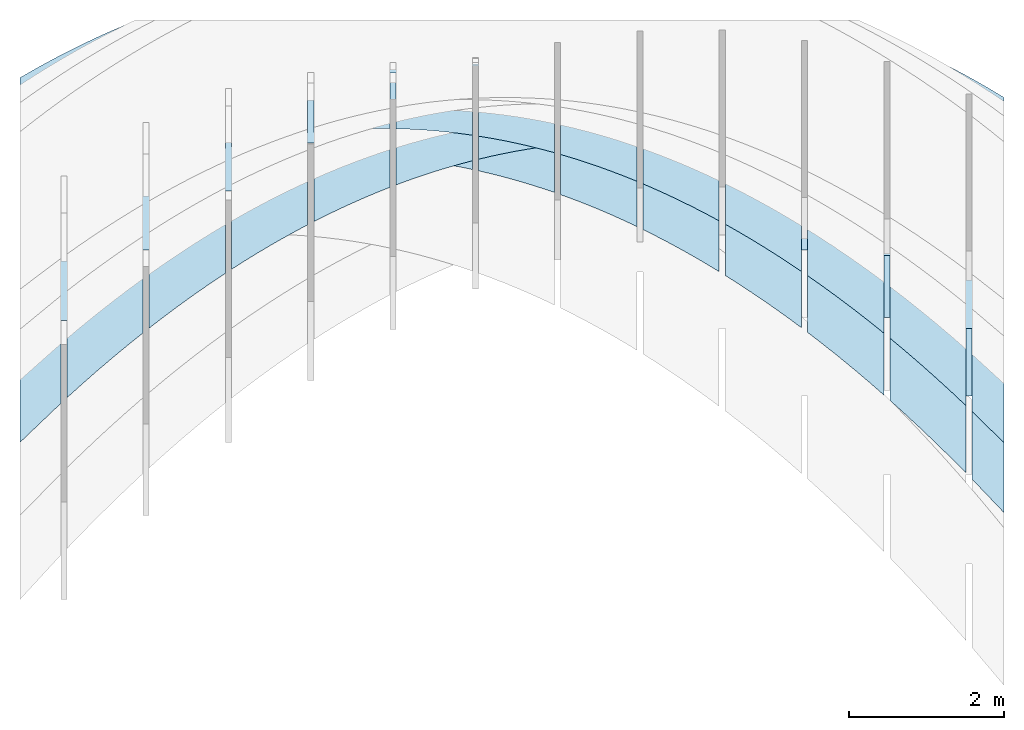
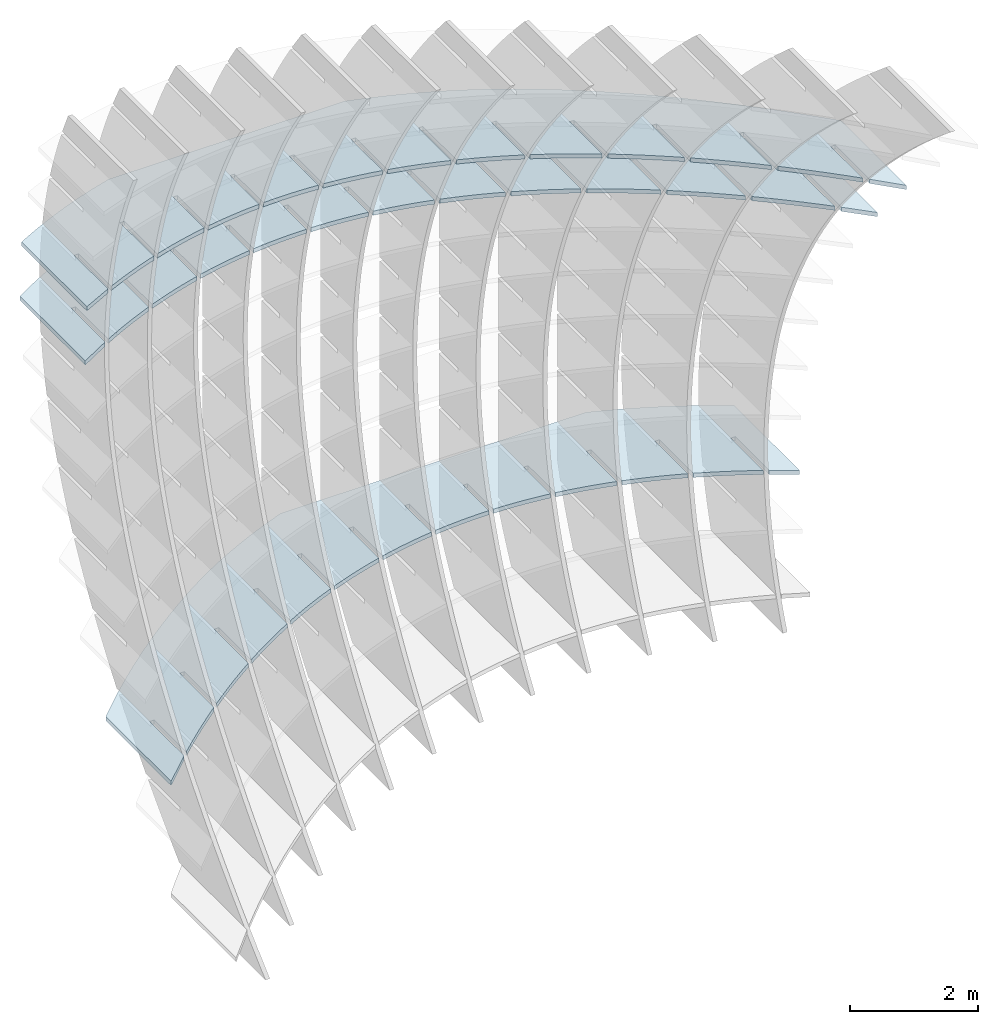
# Not in any storey, part 2 of 9: 3 slabs.
"""IFC2X3 building model written with IfcOpenShell, lengths in metres."""

from ifc_helpers import new_model, si_unit, point, direction, frame, frame_2d, origin_with_axes, place, context, project, spatial, polyline, circle_curve, parameter, trimmed, segment, composite_curve, outline, extrude, material, layer, layer_set, layer_usage, type_object, element, save


model = new_model("IFC2X3")

# Units and contexts
model_context = context("Model", 3, precision=2.54e-06, world=origin_with_axes(), true_north=direction((0.0, 1.0)), identifier="Body")
ifc_project = project(units=[si_unit("LENGTHUNIT", "METRE"), si_unit("AREAUNIT", "SQUARE_METRE"), si_unit("VOLUMEUNIT", "CUBIC_METRE"), si_unit("PLANEANGLEUNIT", "RADIAN")], contexts=[model_context])

# Building
building_placement = place(None, origin_with_axes())
building = spatial("IfcBuilding", under=ifc_project, at=building_placement, Name="Building", CompositionType="ELEMENT")

# Slabs
ifc_material = material(Name="MATERIAL")
ifc_layer = layer(ifc_material, 0.07874, ventilated=True)
ifc_layer_set = layer_set([ifc_layer], Name="SLAB")
ifc_layer_usage_1 = layer_usage(ifc_layer_set, "AXIS3", "NEGATIVE", -0.07874)
slab_type = type_object("IfcSlabType", Name="SLAB", PredefinedType="FLOOR", material=ifc_material)
slab_1_placement = place(None, frame((6.71456553163902, -0.140076335961218, 3.57420189527537), z_axis=(0.0, 0.0, 1.0), x_axis=(-0.89945391, -0.43701564, 0.0)))
element("IfcSlab", 1, at=slab_1_placement, inside=building, type_object=slab_type, material=ifc_layer_usage_1, PredefinedType="FLOOR", context=model_context, shape_type="SweptSolid", body=[
    extrude(outline(composite_curve([segment(polyline([(0.0, 0.0), (0.585873331497038, 0.0)]), True, "CONTINUOUS"), segment(polyline([(0.585873331497038, 0.0), (-0.302142439822155, -1.82769034299806)]), True, "CONTINUOUS"), segment(trimmed(circle_curve(frame_2d((-0.628341243734594, 8.08792664630792), x_axis=(-0.18567938, -0.98261038)), 9.92098109756728), [parameter(0.21964883740824), point((-0.302142439822155, -1.82769034299806))], [parameter(0.0), point((-2.47046284071556, -1.66053240936973))], False, "PARAMETER"), True, "CONTINUOUS"), segment(polyline([(-2.47046284071556, -1.66053240936973), (-6.2862334238149, 0.19342740964954)]), True, "CONTINUOUS"), segment(trimmed(circle_curve(frame_2d((0.781807774238855, 8.17662836836214), x_axis=(-0.86506458, -0.50166051)), 10.6624905122853), [parameter(0.32060910301311), point((-6.2862334238149, 0.19342740964954))], [parameter(0.0), point((-8.44193510839154, 2.82767789563386))], False, "PARAMETER"), True, "CONTINUOUS"), segment(trimmed(circle_curve(frame_2d((4.9780248630452, 10.7740982040003), x_axis=(-0.91693308, -0.399041)), 15.5961829096796), [parameter(0.124145184545443), point((-8.44193510839154, 2.82767789563386))], [parameter(0.0), point((-9.32263121565005, 4.55058174856616))], False, "PARAMETER"), True, "CONTINUOUS"), segment(trimmed(circle_curve(frame_2d((10.2535347681565, 13.0618712359868), x_axis=(-0.95738023, -0.28883058)), 21.3463890005832), [parameter(0.117118469446826), point((-9.32263121565005, 4.55058174856616))], [parameter(0.0), point((-10.1830759507192, 6.89638133741767))], False, "PARAMETER"), True, "CONTINUOUS"), segment(polyline([(-10.1830759507192, 6.89638133741767), (-9.29506017939982, 8.72407168041523)]), True, "CONTINUOUS"), segment(polyline([(-9.29506017939982, 8.72407168041523), (-9.11391498822793, 8.15804572744072)]), True, "CONTINUOUS"), segment(polyline([(-9.11391498822793, 8.15804572744072), (-9.58386503322145, 7.19080709647565)]), True, "CONTINUOUS"), segment(polyline([(-9.58386503322145, 7.19080709647565), (-9.51304203243027, 7.15639648533703)]), True, "CONTINUOUS"), segment(polyline([(-9.51304203243027, 7.15639648533703), (-9.07824061056723, 8.05129315894045)]), True, "CONTINUOUS"), segment(trimmed(circle_curve(frame_2d((10.5986194787214, 14.6501848580907), x_axis=(-0.9481044, -0.31795918)), 20.7538958904239), [parameter(0.0), point((-9.07824061056723, 8.05129315894045))], [parameter(0.0655223084688651), point((-8.60395233100186, 6.77710220115287))], True, "PARAMETER"), True, "CONTINUOUS"), segment(polyline([(-8.60395233100186, 6.77710220115287), (-9.07159581147442, 5.81461087968119)]), True, "CONTINUOUS"), segment(polyline([(-9.07159581147442, 5.81461087968119), (-9.00077281068325, 5.78020026854257)]), True, "CONTINUOUS"), segment(polyline([(-9.00077281068325, 5.78020026854257), (-8.56366488580851, 6.67984412504151)]), True, "CONTINUOUS"), segment(trimmed(circle_curve(frame_2d((7.29840051263215, 13.2814892771154), x_axis=(-0.92323284, -0.38424098)), 17.181002223919), [parameter(0.0), point((-8.56366488580851, 6.67984412504151))], [parameter(0.0740579088368072), point((-8.03172917602346, 5.52430156846033))], True, "PARAMETER"), True, "CONTINUOUS"), segment(polyline([(-8.03172917602346, 5.52430156846033), (-8.49707027378661, 4.56654894958593)]), True, "CONTINUOUS"), segment(polyline([(-8.49707027378661, 4.56654894958593), (-8.42624727299543, 4.53213833844731)]), True, "CONTINUOUS"), segment(polyline([(-8.42624727299543, 4.53213833844731), (-7.98683696541178, 5.43652089754465)]), True, "CONTINUOUS"), segment(trimmed(circle_curve(frame_2d((4.6180486886762, 11.9140727940524), x_axis=(-0.88943013, -0.45707117)), 14.1718672349336), [parameter(0.0), point((-7.98683696541178, 5.43652089754465))], [parameter(0.0842035553852745), point((-7.39738895089196, 4.39934863050301))], True, "PARAMETER"), True, "CONTINUOUS"), segment(polyline([(-7.39738895089196, 4.39934863050301), (-7.86042766594634, 3.44633471422733)]), True, "CONTINUOUS"), segment(polyline([(-7.86042766594634, 3.44633471422733), (-7.78960466515517, 3.41192410308871)]), True, "CONTINUOUS"), segment(polyline([(-7.78960466515517, 3.41192410308871), (-7.34789197486261, 4.32104536478444)]), True, "CONTINUOUS"), segment(trimmed(circle_curve(frame_2d((2.65077584759879, 10.6742793642747), x_axis=(-0.84402661, -0.5363013)), 11.8463893434331), [parameter(0.0), point((-7.34789197486261, 4.32104536478444))], [parameter(0.0948934985891332), point((-6.70093165560826, 3.40224338728277))], True, "PARAMETER"), True, "CONTINUOUS"), segment(polyline([(-6.70093165560826, 3.40224338728277), (-7.16166798795364, 2.4539681736054)]), True, "CONTINUOUS"), segment(polyline([(-7.16166798795364, 2.4539681736054), (-7.09084498716247, 2.41955756246678)]), True, "CONTINUOUS"), segment(polyline([(-7.09084498716247, 2.41955756246678), (-6.646829914161, 3.33341752676089)]), True, "CONTINUOUS"), segment(trimmed(circle_curve(frame_2d((1.29393191304388, 9.61198334810849), x_axis=(-0.78442405, -0.62022488)), 10.1230473262446), [parameter(0.0), point((-6.646829914161, 3.33341752676089))], [parameter(0.10538157879388), point((-5.94235729017195, 2.53298583879896))], True, "PARAMETER"), True, "CONTINUOUS"), segment(polyline([(-5.94235729017195, 2.53298583879896), (-6.4007912398085, 1.58944932772011)]), True, "CONTINUOUS"), segment(polyline([(-6.4007912398085, 1.58944932772011), (-6.32996823901732, 1.55503871658149)]), True, "CONTINUOUS"), segment(polyline([(-6.32996823901732, 1.55503871658149), (-5.88365078330694, 2.473637383474)]), True, "CONTINUOUS"), segment(trimmed(circle_curve(frame_2d((0.444866808654828, 8.77705910587912), x_axis=(-0.70851019, -0.70570058)), 8.93214757615762), [parameter(0.0), point((-5.88365078330694, 2.473637383474))], [parameter(0.114554431580325), point((-5.1216658545834, 1.79157598505202))], True, "PARAMETER"), True, "CONTINUOUS"), segment(polyline([(-5.1216658545834, 1.79157598505202), (-5.55719284104637, 0.895185973767041)]), True, "CONTINUOUS"), segment(polyline([(-5.55719284104637, 0.895185973767041), (-5.48636984025519, 0.860775362628422)]), True, "CONTINUOUS"), segment(polyline([(-5.48636984025519, 0.860775362628422), (-5.05835458230043, 1.74170493492376)]), True, "CONTINUOUS"), segment(trimmed(circle_curve(frame_2d((0.00093045807611101, 8.21938099791285), x_axis=(-0.61553831, -0.78810697)), 8.21928538845074), [parameter(0.0), point((-5.05835458230043, 1.74170493492376))], [parameter(0.121087811880619), point((-4.23885734884193, 1.17801382604141))], True, "PARAMETER"), True, "CONTINUOUS"), segment(polyline([(-4.23885734884193, 1.17801382604141), (-4.63694560262867, 0.358679214420813)]), True, "CONTINUOUS"), segment(polyline([(-4.63694560262867, 0.358679214420813), (-4.5661226018375, 0.324268603282195)]), True, "CONTINUOUS"), segment(polyline([(-4.5661226018375, 0.324268603282195), (-4.17094131114149, 1.13762018111019)]), True, "CONTINUOUS"), segment(trimmed(circle_curve(frame_2d((-0.140527215047963, 7.98882338453596), x_axis=(-0.50704766, -0.86191802)), 7.9487875251903), [parameter(0.0), point((-4.17094131114149, 1.13762018111019))], [parameter(0.123820419877384), point((-3.29393177294847, 0.692299361767771))], True, "PARAMETER"), True, "CONTINUOUS"), segment(polyline([(-3.29393177294847, 0.692299361767771), (-3.68563982913476, -0.113903697557086)]), True, "CONTINUOUS"), segment(polyline([(-3.68563982913476, -0.113903697557086), (-3.61481682834358, -0.148314308695705)]), True, "CONTINUOUS"), segment(polyline([(-3.61481682834358, -0.148314308695705), (-3.2214109698301, 0.661383122033269)]), True, "CONTINUOUS"), segment(trimmed(circle_curve(frame_2d((-0.0821562870734553, 8.13526062607407), x_axis=(-0.3872562, -0.92197215)), 8.10640271073531), [parameter(0.0), point((-3.2214109698301, 0.661383122033269))], [parameter(0.122209681178168), point((-2.28688912690253, 0.334432592230744))], True, "PARAMETER"), True, "CONTINUOUS"), segment(polyline([(-2.28688912690253, 0.334432592230744), (-2.70327552056462, -0.522562762166655)]), True, "CONTINUOUS"), segment(polyline([(-2.70327552056462, -0.522562762166655), (-2.63245251977345, -0.556973373305274)]), True, "CONTINUOUS"), segment(polyline([(-2.63245251977345, -0.556973373305274), (-2.20976355836626, 0.312993757693008)]), True, "CONTINUOUS"), segment(trimmed(circle_curve(frame_2d((0.0733931656439563, 8.70856708285348), x_axis=(-0.26241715, -0.96495453)), 8.70048596829736), [parameter(0.0), point((-2.20976355836626, 0.312993757693008))], [parameter(0.116579560971218), point((-1.21772941070382, 0.104413517430309))], True, "PARAMETER"), True, "CONTINUOUS"), segment(polyline([(-1.21772941070382, 0.104413517430309), (-1.6646514467961, -0.815429480656439)]), True, "CONTINUOUS"), segment(polyline([(-1.6646514467961, -0.815429480656439), (-1.59382844600493, -0.849840091795058)]), True, "CONTINUOUS"), segment(polyline([(-1.59382844600493, -0.849840091795058), (-1.13599907674999, 0.0924520880894061)]), True, "CONTINUOUS"), segment(trimmed(circle_curve(frame_2d((0.218909213086606, 9.71824333562648), x_axis=(-0.1393841, -0.99023839)), 9.72068071767761), [parameter(0.0), point((-1.13599907674999, 0.0924520880894061))], [parameter(0.108426424197185), point((-0.0863961896914924, 0.00235828967910592))], True, "PARAMETER"), True, "CONTINUOUS"), segment(polyline([(-0.0863961896914924, 0.00235828967910592), (-0.530983848137913, -0.912680154684202)]), True, "CONTINUOUS"), segment(polyline([(-0.530983848137913, -0.912680154684202), (-0.460160847346738, -0.947090765822821)]), True, "CONTINUOUS"), segment(polyline([(-0.460160847346738, -0.947090765822821), (0.0, 0.0)]), True, "CONTINUOUS")], self_intersect="UNKNOWN")), origin_with_axes(), (0.0, 0.0, 1.0), 0.07874),
])
ifc_layer_usage_2 = layer_usage(ifc_layer_set, "AXIS3", "NEGATIVE", -0.07874)
slab_2_placement = place(None, frame((6.71456553163902, -0.0529788263679723, 2.51202007709356), z_axis=(0.0, 0.0, 1.0), x_axis=(-0.87518771, -0.48378349, 0.0)))
element("IfcSlab", 2, at=slab_2_placement, inside=building, type_object=slab_type, material=ifc_layer_usage_2, PredefinedType="FLOOR", context=model_context, shape_type="SweptSolid", body=[
    extrude(outline(composite_curve([segment(polyline([(0.0, 0.0), (0.602117750692325, 0.0)]), True, "CONTINUOUS"), segment(polyline([(0.602117750692325, 0.0), (-0.380930298803925, -1.77838143613276)]), True, "CONTINUOUS"), segment(trimmed(circle_curve(frame_2d((-0.701672837617832, 9.33917503804688), x_axis=(-0.12258478, -0.99245805)), 11.1221822378874), [parameter(0.151735983691604), point((-0.380930298803925, -1.77838143613276))], [parameter(0.0), point((-2.06508312120013, -1.69912420284166))], False, "PARAMETER"), True, "CONTINUOUS"), segment(polyline([(-2.06508312120013, -1.69912420284166), (-7.60206642982983, 1.36159186799111)]), True, "CONTINUOUS"), segment(trimmed(circle_curve(frame_2d((1.52024790809472, 8.7365306049556), x_axis=(-0.89786861, -0.44026351)), 11.7305728868578), [parameter(0.223980294822697), point((-7.60206642982983, 1.36159186799111))], [parameter(0.0), point((-9.01226526921654, 3.57198740892675))], False, "PARAMETER"), True, "CONTINUOUS"), segment(trimmed(circle_curve(frame_2d((7.06616798963945, 11.4495359195691), x_axis=(-0.96433258, -0.26469356)), 17.9045186083572), [parameter(0.187685195515794), point((-9.01226526921654, 3.57198740892675))], [parameter(0.0), point((-10.1997425931127, 6.71032518935079))], False, "PARAMETER"), True, "CONTINUOUS"), segment(polyline([(-10.1997425931127, 6.71032518935079), (-9.21669454361677, 8.48870662548464)]), True, "CONTINUOUS"), segment(polyline([(-9.21669454361677, 8.48870662548464), (-9.05233249389115, 7.93795137802405)]), True, "CONTINUOUS"), segment(polyline([(-9.05233249389115, 7.93795137802405), (-9.57130052752341, 6.99911312140895)]), True, "CONTINUOUS"), segment(polyline([(-9.57130052752341, 6.99911312140895), (-9.50238824687327, 6.96102000949097)]), True, "CONTINUOUS"), segment(polyline([(-9.50238824687327, 6.96102000949097), (-9.01978154107163, 7.83407886657391)]), True, "CONTINUOUS"), segment(trimmed(circle_curve(frame_2d((8.89416164906669, 13.4703708563373), x_axis=(-0.95389931, -0.30012683)), 18.7797004239517), [parameter(0.0), point((-9.01978154107163, 7.83407886657391))], [parameter(0.0700381036296315), point((-8.5814299966057, 6.59426406200381))], True, "PARAMETER"), True, "CONTINUOUS"), segment(polyline([(-8.5814299966057, 6.59426406200381), (-9.0978446254152, 5.66004503813134)]), True, "CONTINUOUS"), segment(polyline([(-9.0978446254152, 5.66004503813134), (-9.02893234476506, 5.62195192621336)]), True, "CONTINUOUS"), segment(polyline([(-9.02893234476506, 5.62195192621336), (-8.54377230223221, 6.49962989285591)]), True, "CONTINUOUS"), segment(trimmed(circle_curve(frame_2d((5.92689042038512, 12.2882352564975), x_axis=(-0.92846916, -0.3714095)), 15.5855071039645), [parameter(0.0), point((-8.54377230223221, 6.49962989285591))], [parameter(0.0790306201356163), point((-8.04160410533061, 5.37526249705626))], True, "PARAMETER"), True, "CONTINUOUS"), segment(polyline([(-8.04160410533061, 5.37526249705626), (-8.55546995865093, 4.4456543312326)]), True, "CONTINUOUS"), segment(polyline([(-8.55546995865093, 4.4456543312326), (-8.48655767800079, 4.40756121931462)]), True, "CONTINUOUS"), segment(polyline([(-8.48655767800079, 4.40756121931462), (-7.99884885997961, 5.28985004400794)]), True, "CONTINUOUS"), segment(trimmed(circle_curve(frame_2d((3.55012754085237, 11.1019340305125), x_axis=(-0.89326102, -0.44953837)), 12.9290052275168), [parameter(0.0), point((-7.99884885997961, 5.28985004400794))], [parameter(0.0895181356163756), point((-7.4330135967737, 4.28065944843164))], True, "PARAMETER"), True, "CONTINUOUS"), segment(polyline([(-7.4330135967737, 4.28065944843164), (-7.9443306746062, 3.3556621406597)]), True, "CONTINUOUS"), segment(polyline([(-7.9443306746062, 3.3556621406597), (-7.87541839395605, 3.31756902874172)]), True, "CONTINUOUS"), segment(polyline([(-7.87541839395605, 3.31756902874172), (-7.38516080044654, 4.20446871148582)]), True, "CONTINUOUS"), segment(trimmed(circle_curve(frame_2d((1.84223544822343, 10.0331265424631), x_axis=(-0.84545462, -0.53404726)), 10.9141235855465), [parameter(0.0), point((-7.38516080044654, 4.20446871148582))], [parameter(0.100224490208268), point((-6.75565847085051, 3.31045491602374))], True, "PARAMETER"), True, "CONTINUOUS"), segment(polyline([(-6.75565847085051, 3.31045491602374), (-7.26442677336936, 2.39006846598608)]), True, "CONTINUOUS"), segment(polyline([(-7.26442677336936, 2.39006846598608), (-7.19551449271922, 2.3519753540681)]), True, "CONTINUOUS"), segment(polyline([(-7.19551449271922, 2.3519753540681), (-6.70270812354593, 3.24348589518036)]), True, "CONTINUOUS"), segment(trimmed(circle_curve(frame_2d((0.703333443046179, 9.13702452882004), x_axis=(-0.78247909, -0.62267686)), 9.46484280441538), [parameter(0.0), point((-6.70270812354593, 3.24348589518036))], [parameter(0.110213642357408), point((-6.0095387278199, 2.46464890016233))], True, "PARAMETER"), True, "CONTINUOUS"), segment(polyline([(-6.0095387278199, 2.46464890016233), (-6.44137518259479, 1.68343588111274)]), True, "CONTINUOUS"), segment(polyline([(-6.44137518259479, 1.68343588111274), (-6.37246290194465, 1.64534276919476)]), True, "CONTINUOUS"), segment(polyline([(-6.37246290194465, 1.64534276919476), (-5.95149082953902, 2.40690159541912)]), True, "CONTINUOUS"), segment(trimmed(circle_curve(frame_2d((0.0335408255752165, 8.46883972590842), x_axis=(-0.70257838, -0.71160637)), 8.51866760770718), [parameter(0.0), point((-5.95149082953902, 2.40690159541912))], [parameter(0.118233031779902), point((-5.19465436742192, 1.74324140051601))], True, "PARAMETER"), True, "CONTINUOUS"), segment(polyline([(-5.19465436742192, 1.74324140051601), (-5.56785437566248, 1.06810454737854)]), True, "CONTINUOUS"), segment(polyline([(-5.56785437566248, 1.06810454737854), (-5.49894209501234, 1.03001143546056)]), True, "CONTINUOUS"), segment(polyline([(-5.49894209501234, 1.03001143546056), (-5.13150891816456, 1.69471581187454)]), True, "CONTINUOUS"), segment(trimmed(circle_curve(frame_2d((-0.267023103921782, 8.08378386998206), x_axis=(-0.60577721, -0.79563432)), 8.03015646722397), [parameter(0.0), point((-5.13150891816456, 1.69471581187454))], [parameter(0.122982293439981), point((-4.31100538974349, 1.14623241719563))], True, "PARAMETER"), True, "CONTINUOUS"), segment(polyline([(-4.31100538974349, 1.14623241719563), (-4.65995126008994, 0.514972471807271)]), True, "CONTINUOUS"), segment(polyline([(-4.65995126008994, 0.514972471807271), (-4.5910389794398, 0.476879359889291)]), True, "CONTINUOUS"), segment(polyline([(-4.5910389794398, 0.476879359889291), (-4.24276238950963, 1.10692854465582)]), True, "CONTINUOUS"), segment(trimmed(circle_curve(frame_2d((-0.298239045043792, 8.03706869743882), x_axis=(-0.49466754, -0.86908229)), 7.9740897256208), [parameter(0.0), point((-4.24276238950963, 1.10692854465582))], [parameter(0.123558271913986), point((-3.35859179478477, 0.673621950201216))], True, "PARAMETER"), True, "CONTINUOUS"), segment(polyline([(-3.35859179478477, 0.673621950201216), (-3.71766583587716, 0.0240396543989242)]), True, "CONTINUOUS"), segment(polyline([(-3.71766583587716, 0.0240396543989242), (-3.64875355522702, -0.0140534575190553)]), True, "CONTINUOUS"), segment(polyline([(-3.64875355522702, -0.0140534575190553), (-3.28525124357423, 0.643539793762937)]), True, "CONTINUOUS"), segment(trimmed(circle_curve(frame_2d((-0.1599876974445, 8.38390594462594), x_axis=(-0.37439573, -0.92726902)), 8.34748706990272), [parameter(0.0), point((-3.28525124357423, 0.643539793762937))], [parameter(0.119844445167164), point((-2.33741358254598, 0.325409999532763))], True, "PARAMETER"), True, "CONTINUOUS"), segment(polyline([(-2.33741358254598, 0.325409999532763), (-2.74099810302416, -0.404693904846497)]), True, "CONTINUOUS"), segment(polyline([(-2.74099810302416, -0.404693904846497), (-2.67208582237401, -0.442787016764476)]), True, "CONTINUOUS"), segment(polyline([(-2.67208582237401, -0.442787016764476), (-2.25897548035838, 0.304549559195908)]), True, "CONTINUOUS"), segment(trimmed(circle_curve(frame_2d((0.0478502392226175, 9.17950734789114), x_axis=(-0.2515661, -0.96784012)), 9.16985935833493), [parameter(0.0), point((-2.25897548035838, 0.304549559195908))], [parameter(0.112565458213443), point((-1.24747075302604, 0.101596565189948))], True, "PARAMETER"), True, "CONTINUOUS"), segment(polyline([(-1.24747075302604, 0.101596565189948), (-1.72994806153092, -0.771228205928994)]), True, "CONTINUOUS"), segment(polyline([(-1.72994806153092, -0.771228205928994), (-1.66103578088077, -0.809321317846974)]), True, "CONTINUOUS"), segment(polyline([(-1.66103578088077, -0.809321317846974), (-1.16393509986206, 0.0899578409547249)]), True, "CONTINUOUS"), segment(trimmed(circle_curve(frame_2d((0.220740987062979, 10.4357432376187), x_axis=(-0.13265676, -0.99116204)), 10.4380363737404), [parameter(0.0), point((-1.16393509986206, 0.0899578409547249))], [parameter(0.10339901101634), point((-0.0887008321285592, 0.00229466583462862))], True, "PARAMETER"), True, "CONTINUOUS"), segment(polyline([(-0.0887008321285592, 0.00229466583462862), (-0.579592287133205, -0.885751702991141)]), True, "CONTINUOUS"), segment(polyline([(-0.579592287133205, -0.885751702991141), (-0.51068000648306, -0.923844814909121)]), True, "CONTINUOUS"), segment(polyline([(-0.51068000648306, -0.923844814909121), (0.0, 0.0)]), True, "CONTINUOUS")], self_intersect="UNKNOWN")), origin_with_axes(), (0.0, 0.0, 1.0), 0.07874),
])
ifc_layer_usage_3 = layer_usage(ifc_layer_set, "AXIS3", "NEGATIVE", -0.07874)
slab_3_placement = place(None, frame((6.71456553163902, -2.51531780186635, -3.86107083199735), z_axis=(0.0, 0.0, 1.0), x_axis=(-0.72346903, -0.69035684, 0.0)))
element("IfcSlab", 3, at=slab_3_placement, inside=building, type_object=slab_type, material=ifc_layer_usage_3, PredefinedType="FLOOR", context=model_context, shape_type="SweptSolid", body=[
    extrude(outline(composite_curve([segment(polyline([(0.0, 0.0), (0.728387864054687, 0.0)]), True, "CONTINUOUS"), segment(polyline([(0.728387864054687, 0.0), (-0.674417238737719, -1.4700890597442)]), True, "CONTINUOUS"), segment(trimmed(circle_curve(frame_2d((-1.13321816050628, 15.6831863165129), x_axis=(-0.1753304, -0.98450965)), 17.1594100836691), [parameter(0.202982115821907), point((-0.674417238737719, -1.4700890597442))], [parameter(0.0), point((-4.14178444025825, -1.21041849003633))], False, "PARAMETER"), True, "CONTINUOUS"), segment(trimmed(circle_curve(frame_2d((-2.18935215201853, 9.72213432950427), x_axis=(-0.40978818, -0.91218071)), 11.1055257863915), [parameter(0.245496070369312), point((-4.14178444025825, -1.21041849003633))], [parameter(0.0), point((-6.74026529662025, -0.408112091116376))], False, "PARAMETER"), True, "CONTINUOUS"), segment(polyline([(-6.74026529662025, -0.408112091116376), (-10.7056766701919, 3.37580785077149)]), True, "CONTINUOUS"), segment(trimmed(circle_curve(frame_2d((-1.04322165013471, 8.29959445518439), x_axis=(-0.9672527, -0.25381533)), 10.8446628135883), [parameter(0.214658880295852), point((-10.7056766701919, 3.37580785077149))], [parameter(0.0), point((-11.5327509884727, 5.54705275694027))], False, "PARAMETER"), True, "CONTINUOUS"), segment(polyline([(-11.5327509884727, 5.54705275694027), (-10.1299458856803, 7.01714181668475)]), True, "CONTINUOUS"), segment(polyline([(-10.1299458856803, 7.01714181668475), (-9.99726688547349, 6.56186307420687)]), True, "CONTINUOUS"), segment(polyline([(-9.99726688547349, 6.56186307420687), (-10.7269206397842, 5.79721230448964)]), True, "CONTINUOUS"), segment(polyline([(-10.7269206397842, 5.79721230448964), (-10.6699546887191, 5.74285360675643)]), True, "CONTINUOUS"), segment(polyline([(-10.6699546887191, 5.74285360675643), (-9.97036583782267, 6.47599744403978)]), True, "CONTINUOUS"), segment(trimmed(circle_curve(frame_2d((0.334185883815589, 9.72696064800664), x_axis=(-0.95366517, -0.30086999)), 10.8052092963285), [parameter(0.0), point((-9.97036583782267, 6.47599744403978))], [parameter(0.101248118094036), point((-9.58900220232285, 5.45111147566851))], True, "PARAMETER"), True, "CONTINUOUS"), segment(polyline([(-9.58900220232285, 5.45111147566851), (-10.315012259545, 4.69027916884028)]), True, "CONTINUOUS"), segment(polyline([(-10.315012259545, 4.69027916884028), (-10.25804630848, 4.63592047110707)]), True, "CONTINUOUS"), segment(polyline([(-10.25804630848, 4.63592047110707), (-9.55481385766231, 5.37288266945255)]), True, "CONTINUOUS"), segment(trimmed(circle_curve(frame_2d((-0.89395245154325, 9.19030706525925), x_axis=(-0.91505602, -0.40332676)), 9.46484280448982), [parameter(0.0), point((-9.55481385766231, 5.37288266945255))], [parameter(0.110213642371296), point((-9.08238414891488, 4.44343065532585))], True, "PARAMETER"), True, "CONTINUOUS"), segment(polyline([(-9.08238414891488, 4.44343065532585), (-9.75288264312781, 3.74077246071607)]), True, "CONTINUOUS"), segment(polyline([(-9.75288264312781, 3.74077246071607), (-9.69591669206272, 3.68641376298286)]), True, "CONTINUOUS"), segment(polyline([(-9.69591669206272, 3.68641376298286), (-9.04092162215793, 4.37282492910756)]), True, "CONTINUOUS"), segment(trimmed(circle_curve(frame_2d((-1.71159089111161, 8.71432338534869), x_axis=(-0.86038464, -0.50964525)), 8.51866760770745), [parameter(0.0), point((-9.04092162215793, 4.37282492910756))], [parameter(0.118233031779899), point((-8.4776392988957, 3.53858317218821))], True, "PARAMETER"), True, "CONTINUOUS"), segment(polyline([(-8.4776392988957, 3.53858317218821), (-9.06446385016072, 2.92361224637098)]), True, "CONTINUOUS"), segment(polyline([(-9.06446385016072, 2.92361224637098), (-9.00749789909563, 2.86925354863777)]), True, "CONTINUOUS"), segment(polyline([(-9.00749789909563, 2.86925354863777), (-8.4289025900417, 3.4756005259665)]), True, "CONTINUOUS"), segment(trimmed(circle_curve(frame_2d((-2.10015977053342, 8.41831508505432), x_axis=(-0.78812198, -0.61551908)), 8.0301564672238), [parameter(0.0), point((-8.4289025900417, 3.4756005259665))], [parameter(0.122982293439984), point((-7.77476765226378, 2.73656902625339))], True, "PARAMETER"), True, "CONTINUOUS"), segment(polyline([(-7.77476765226378, 2.73656902625339), (-8.32698165888769, 2.15786870062786)]), True, "CONTINUOUS"), segment(polyline([(-8.32698165888769, 2.15786870062786), (-8.2700157078226, 2.10351000289465)]), True, "CONTINUOUS"), segment(polyline([(-8.2700157078226, 2.10351000289465), (-7.71875676131361, 2.68120946002937)]), True, "CONTINUOUS"), segment(trimmed(circle_curve(frame_2d((-2.14222491109737, 8.3810690614382), x_axis=(-0.69933147, -0.71479753)), 7.97408972562063), [parameter(0.0), point((-7.71875676131361, 2.68120946002937))], [parameter(0.123558271913988), point((-6.97376920902049, 2.03738821752312))], True, "PARAMETER"), True, "CONTINUOUS"), segment(polyline([(-6.97376920902049, 2.03738821752312), (-7.54043606930874, 1.4435418234867)]), True, "CONTINUOUS"), segment(polyline([(-7.54043606930874, 1.4435418234867), (-7.48347011824366, 1.3891831257535)]), True, "CONTINUOUS"), segment(polyline([(-7.48347011824366, 1.3891831257535), (-6.91048413597366, 1.98965173129617)]), True, "CONTINUOUS"), segment(trimmed(circle_curve(frame_2d((-1.92035213409343, 8.68137221156145), x_axis=(-0.59780051, -0.80164491)), 8.34748706990259), [parameter(0.0), point((-6.91048413597366, 1.98965173129617))], [parameter(0.119844445167167), point((-6.07464396916571, 1.44104074599699))], True, "PARAMETER"), True, "CONTINUOUS"), segment(polyline([(-6.07464396916571, 1.44104074599699), (-6.70482708142386, 0.7806316149475)]), True, "CONTINUOUS"), segment(polyline([(-6.70482708142386, 0.7806316149475), (-6.64786113035877, 0.726272917214294)]), True, "CONTINUOUS"), segment(polyline([(-6.64786113035877, 0.726272917214294), (-6.00408471402185, 1.40092733976688)]), True, "CONTINUOUS"), segment(trimmed(circle_curve(frame_2d((-1.51710726081077, 9.39801143248625), x_axis=(-0.48931802, -0.87210542)), 9.16985935833531), [parameter(0.0), point((-6.00408471402185, 1.40092733976688))], [parameter(0.112565458213438), point((-5.07739193269806, 0.947526611674245))], True, "PARAMETER"), True, "CONTINUOUS"), segment(polyline([(-5.07739193269806, 0.947526611674245), (-5.78157944363091, 0.209563544838035)]), True, "CONTINUOUS"), segment(polyline([(-5.78157944363091, 0.209563544838035), (-5.72461349256582, 0.15520484710483)]), True, "CONTINUOUS"), segment(polyline([(-5.72461349256582, 0.15520484710483), (-4.99955849545818, 0.915036285441525)]), True, "CONTINUOUS"), segment(trimmed(circle_curve(frame_2d((-1.01505611253974, 10.6097736212725), x_axis=(-0.38014213, -0.92492808)), 10.4816120539847), [parameter(0.0), point((-4.99955849545818, 0.915036285441525))], [parameter(0.102963694064149), point((-3.98201309962036, 0.556845814556126))], True, "PARAMETER"), True, "CONTINUOUS"), segment(polyline([(-3.98201309962036, 0.556845814556126), (-4.68256351950371, -0.177305712281933)]), True, "CONTINUOUS"), segment(polyline([(-4.68256351950371, -0.177305712281933), (-4.62559756843862, -0.231664410015138)]), True, "CONTINUOUS"), segment(polyline([(-4.62559756843862, -0.231664410015138), (-3.89690548028265, 0.53197856832009)]), True, "CONTINUOUS"), segment(trimmed(circle_curve(frame_2d((-0.496764510569062, 12.3954456749835), x_axis=(-0.27551355, -0.96129719)), 12.3411024793091), [parameter(0.0), point((-3.89690548028265, 0.53197856832009))], [parameter(0.0923396645129887), point((-2.78850746992848, 0.268998354641235))], True, "PARAMETER"), True, "CONTINUOUS"), segment(polyline([(-2.78850746992848, 0.268998354641235), (-3.48542079876466, -0.461341632197979)]), True, "CONTINUOUS"), segment(polyline([(-3.48542079876466, -0.461341632197979), (-3.42845484769957, -0.515700329931185)]), True, "CONTINUOUS"), segment(polyline([(-3.42845484769957, -0.515700329931185), (-2.69612566849526, 0.251754188402583)]), True, "CONTINUOUS"), segment(trimmed(circle_curve(frame_2d((-0.0447982761889302, 14.8338144906788), x_axis=(-0.17888829, -0.98386939)), 14.8211342211187), [parameter(0.0), point((-2.69612566849526, 0.251754188402583))], [parameter(0.0817255920081469), point((-1.49687504362728, 0.0839842319307499))], True, "PARAMETER"), True, "CONTINUOUS"), segment(polyline([(-1.49687504362728, 0.0839842319307499), (-2.19015128141374, -0.642544214910099)]), True, "CONTINUOUS"), segment(polyline([(-2.19015128141374, -0.642544214910099), (-2.13318533034865, -0.696902912643306)]), True, "CONTINUOUS"), segment(polyline([(-2.13318533034865, -0.696902912643306), (-1.39721906009602, 0.0743631456889991)]), True, "CONTINUOUS"), segment(trimmed(circle_curve(frame_2d((0.252763522981146, 17.9291669913539), x_axis=(-0.09201905, -0.99575725)), 17.9308801482701), [parameter(0.0), point((-1.39721906009602, 0.0743631456889991))], [parameter(0.0720826690361117), point((-0.107026670456748, 0.00189687266784386))], True, "PARAMETER"), True, "CONTINUOUS"), segment(polyline([(-0.107026670456748, 0.00189687266784386), (-0.796615274558281, -0.720767067314323)]), True, "CONTINUOUS"), segment(polyline([(-0.796615274558281, -0.720767067314323), (-0.739649323493193, -0.775125765047529)]), True, "CONTINUOUS"), segment(polyline([(-0.739649323493193, -0.775125765047529), (0.0, 0.0)]), True, "CONTINUOUS")], self_intersect="UNKNOWN")), origin_with_axes(), (0.0, 0.0, 1.0), 0.07874),
])

save(model, "model.ifc")
